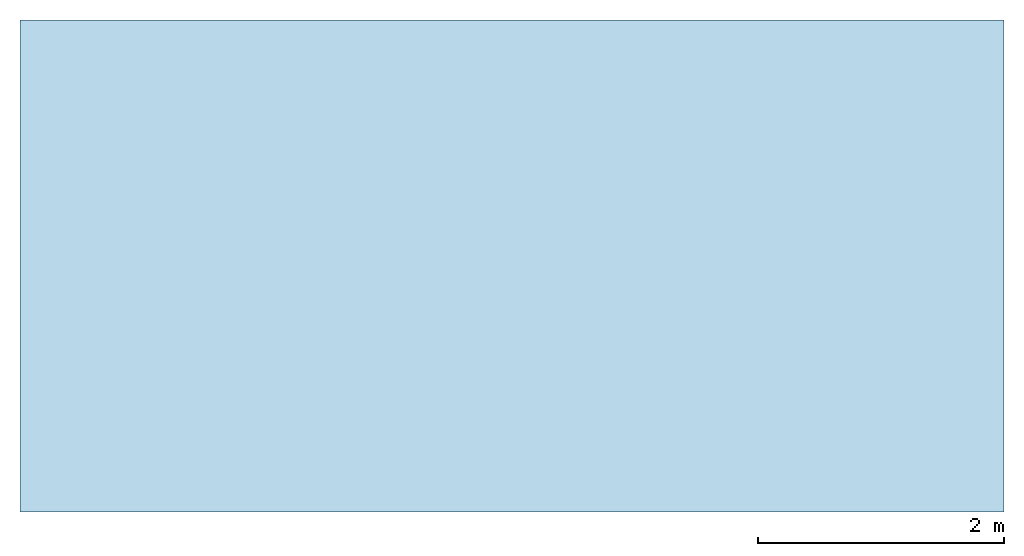
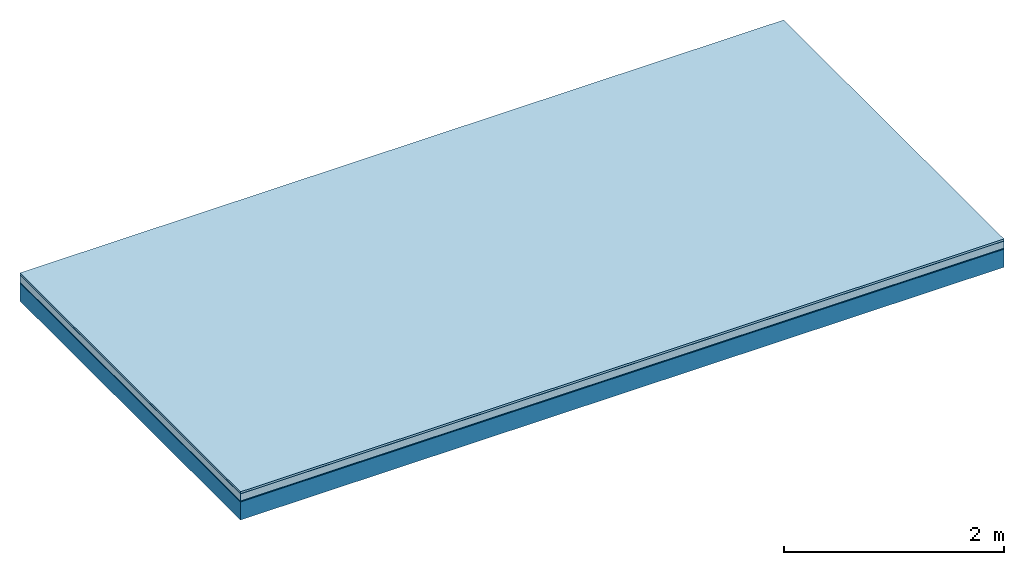
# One storey: 5 plates, 1 member, 1 element without a shape of its own.
"""IFC4 building model written with IfcOpenShell, lengths in metres."""

import ifcopenshell
import ifcopenshell.guid

model = None  # the IFC model being written
_history = None  # IfcOwnerHistory: only IFC2X3 demands one
_inside = {}  # id of a spatial element -> (the spatial element, [elements in it])
_under = {}  # id of a project, library or spatial element -> (it, [spatial elements below it])
_declared = {}  # id of a project -> (the project, [libraries it declares])
_typed = {}  # id of a type object -> (the type object, [elements of that type])
_made_of = {}  # id of a material, layer set ... -> (it, [elements and type objects made of it])


def new_model(schema):
    """Start an empty IFC model of exactly this schema.

    Asked for "IFC4X3", IfcOpenShell would pick the latest addendum, in which some entities
    have other attributes; the version numbers below select the first issue.
    IFC2X3 requires an IfcOwnerHistory on every rooted entity: one is made here for all.
    """
    global model, _history
    if schema == "IFC4X3":
        model = ifcopenshell.file(schema_version=(4, 3, 0, 0))
    else:
        model = ifcopenshell.file(schema=schema)
    _inside.clear()
    _under.clear()
    _declared.clear()
    _typed.clear()
    _made_of.clear()
    _history = None
    if model.schema == "IFC2X3":
        org = make("IfcOrganization", Name="unknown")
        user = make(
            "IfcPersonAndOrganization",
            ThePerson=make("IfcPerson", FamilyName="unknown"),
            TheOrganization=org,
        )
        app = make(
            "IfcApplication",
            ApplicationDeveloper=org,
            Version="unknown",
            ApplicationFullName="unknown",
            ApplicationIdentifier="unknown",
        )
        _history = make(
            "IfcOwnerHistory",
            OwningUser=user,
            OwningApplication=app,
            ChangeAction="ADDED",
            CreationDate=0,
        )
    return model


def make(cls, **values):
    """One entity of the class cls with the attributes given. An attribute that is None is left unset."""
    return model.create_entity(
        cls, **{name: value for name, value in values.items() if value is not None}
    )


def rooted(cls, **values):
    """An entity with a GlobalId (a new one), such as an element, a storey or a relation."""
    return make(cls, GlobalId=ifcopenshell.guid.new(), OwnerHistory=_history, **values)


def si_unit(unit_type, name, prefix=None):
    """IfcSIUnit, for example si_unit("LENGTHUNIT", "METRE", prefix="MILLI")."""
    return make("IfcSIUnit", UnitType=unit_type, Prefix=prefix, Name=name)


def derived_unit(unit_type, elements):
    """IfcDerivedUnit: a product of units, each with its exponent."""
    return make(
        "IfcDerivedUnit",
        Elements=[
            make("IfcDerivedUnitElement", Unit=unit, Exponent=power)
            for unit, power in elements
        ],
        UnitType=unit_type,
    )


def assignment(units):
    """IfcUnitAssignment: the units of a project."""
    return None if units is None else make("IfcUnitAssignment", Units=units)


def point(xyz):
    """IfcCartesianPoint."""
    return None if xyz is None else make("IfcCartesianPoint", Coordinates=xyz)


def direction(xyz):
    """IfcDirection."""
    return None if xyz is None else make("IfcDirection", DirectionRatios=xyz)


def frame(location, z_axis=None, x_axis=None):
    """IfcAxis2Placement3D, a coordinate frame: its origin and axes. An axis left out is left unset."""
    return make(
        "IfcAxis2Placement3D",
        Location=point(location),
        Axis=direction(z_axis),
        RefDirection=direction(x_axis),
    )


def frame_2d(location, x_axis=None):
    """IfcAxis2Placement2D, a coordinate frame in the plane: its origin and x axis."""
    return make(
        "IfcAxis2Placement2D", Location=point(location), RefDirection=direction(x_axis)
    )


def origin():
    """The frame at (0, 0, 0) with its axes left unset."""
    return frame((0.0, 0.0, 0.0))


def origin_with_axes():
    """The frame at (0, 0, 0) with the z axis (0, 0, 1) and the x axis (1, 0, 0) written out."""
    return frame((0.0, 0.0, 0.0), z_axis=(0.0, 0.0, 1.0), x_axis=(1.0, 0.0, 0.0))


def place(relative_to, where):
    """IfcLocalPlacement: puts the frame where relative to a parent placement (None: the world)."""
    return make(
        "IfcLocalPlacement", PlacementRelTo=relative_to, RelativePlacement=where
    )


def context(
    kind, dimensions, precision=None, world=None, true_north=None, identifier=None
):
    """IfcGeometricRepresentationContext, for example the 3D "Model" context."""
    return make(
        "IfcGeometricRepresentationContext",
        ContextIdentifier=identifier,
        ContextType=kind,
        CoordinateSpaceDimension=dimensions,
        Precision=precision,
        WorldCoordinateSystem=world,
        TrueNorth=true_north,
    )


def project(units=None, contexts=None):
    """IfcProject with its units and contexts."""
    return rooted(
        "IfcProject",
        Name="project",
        RepresentationContexts=contexts,
        UnitsInContext=assignment(units),
    )


def spatial(cls, under=None, at=None, **own):
    """A site, building, storey or space (cls), placed at a placement, below another one or the project."""
    s = rooted(cls, ObjectPlacement=at, **own)
    if under is not None:
        _under.setdefault(under.id(), (under, []))[1].append(s)
    return s


def profile(cls, at=None, kind="AREA", **sizes):
    """A parametric profile (cls). Its sizes go by their IFC names, for example OverallWidth=200.0."""
    return make(cls, ProfileType=kind, Position=at, **sizes)


def rectangle(**sizes):
    """IfcRectangleProfileDef."""
    return profile("IfcRectangleProfileDef", **sizes)


def extrude(swept, where, along, depth):
    """IfcExtrudedAreaSolid: the profile swept, set in the frame where, extruded along a direction by depth."""
    return make(
        "IfcExtrudedAreaSolid",
        SweptArea=swept,
        Position=where,
        ExtrudedDirection=direction(along),
        Depth=depth,
    )


def shape(context_of_items, identifier, shape_type, items):
    """IfcShapeRepresentation: the items that make up one representation, for example the "Body"."""
    return make(
        "IfcShapeRepresentation",
        ContextOfItems=context_of_items,
        RepresentationIdentifier=identifier,
        RepresentationType=shape_type,
        Items=items,
    )


def material(Name=None, Category=None):
    """IfcMaterial."""
    return make("IfcMaterial", Name=Name, Category=Category)


def layer(
    of_material, thickness, ventilated=None, Name=None, Category=None, Priority=None
):
    """IfcMaterialLayer: one layer of a wall or slab, of a material (None: an air gap)."""
    return make(
        "IfcMaterialLayer",
        Material=of_material,
        LayerThickness=thickness,
        IsVentilated=ventilated,
        Name=Name,
        Category=Category,
        Priority=Priority,
    )


def layer_set(layers, Name=None):
    """IfcMaterialLayerSet."""
    return make("IfcMaterialLayerSet", MaterialLayers=layers, LayerSetName=Name)


def made_of(thing, what):
    """Note that an element or type object is made of a material, layer set ...; save() writes the relation."""
    if what is not None:
        _made_of.setdefault(what.id(), (what, []))[1].append(thing)
    return thing


def type_object(cls, material=None, **own):
    """A type object (cls), such as IfcWallType, which elements share."""
    return made_of(rooted(cls, **own), material)


def element(
    cls,
    number,
    at=None,
    inside=None,
    cuts=None,
    type_object=None,
    material=None,
    context=None,
    identifier="Body",
    shape_type=None,
    held_by="IfcProductDefinitionShape",
    body=None,
    shapes=None,
    **own,
):
    """One element of the class cls, such as IfcWall. Its Tag is "e" and its number.

    at: its placement. inside: the storey or other place that contains it. cuts: it is an
    opening in that element (IfcRelVoidsElement). A single representation is given by context,
    identifier, shape_type and body (its items); several are given by shapes. held_by: the class
    of the entity that holds the representations. save() writes the other relations.
    """
    e = rooted(cls, Tag="e%d" % number, ObjectPlacement=at, **own)
    if body is not None:
        shapes = [shape(context, identifier, shape_type, body)]
    if shapes is not None:
        e.Representation = make(held_by, Representations=shapes)
    if inside is not None:
        _inside.setdefault(inside.id(), (inside, []))[1].append(e)
    if cuts is not None:
        rooted(
            "IfcRelVoidsElement", RelatingBuildingElement=cuts, RelatedOpeningElement=e
        )
    if type_object is not None:
        _typed.setdefault(type_object.id(), (type_object, []))[1].append(e)
    return made_of(e, material)


def aggregate(whole, parts):
    """IfcRelAggregates: a whole, such as a stair, and the parts it consists of."""
    return rooted("IfcRelAggregates", RelatingObject=whole, RelatedObjects=parts)


def save(model, path):
    """Write the relations noted so far, then the file.

    IfcRelAggregates (storeys below a building ...), IfcRelContainedInSpatialStructure (elements
    in a storey), IfcRelDefinesByType, IfcRelAssociatesMaterial and IfcRelDeclares: one each for
    every whole, place, type object, material and project.
    """
    for whole, parts in _under.values():
        aggregate(whole, parts)
    for where, things in _inside.values():
        rooted(
            "IfcRelContainedInSpatialStructure",
            RelatedElements=things,
            RelatingStructure=where,
        )
    for kind, things in _typed.values():
        rooted("IfcRelDefinesByType", RelatedObjects=things, RelatingType=kind)
    for what, things in _made_of.values():
        rooted("IfcRelAssociatesMaterial", RelatedObjects=things, RelatingMaterial=what)
    for by, libraries in _declared.values():
        rooted("IfcRelDeclares", RelatingContext=by, RelatedDefinitions=libraries)
    model.write(path)


model = new_model("IFC4")

# Units and contexts
plan_context = context("Plan", 3, precision=1e-05, world=origin(), true_north=direction((0.0, 1.0)))
model_context = context("Model", 3, precision=1e-05, world=origin(), true_north=direction((0.0, 1.0)))
ifc_project = project(units=[si_unit("LENGTHUNIT", "METRE"), derived_unit("SOUNDPRESSUREUNIT", [(si_unit("PRESSUREUNIT", "PASCAL", prefix="MICRO"), 0)]), si_unit("ENERGYUNIT", "JOULE", prefix="MEGA"), si_unit("MASSUNIT", "GRAM", prefix="KILO"), derived_unit("THERMALTRANSMITTANCEUNIT", [(si_unit("POWERUNIT", "WATT"), 1), (si_unit("AREAUNIT", "SQUARE_METRE"), -1), (si_unit("THERMODYNAMICTEMPERATUREUNIT", "KELVIN"), -1)]), derived_unit("AREADENSITYUNIT", [(si_unit("MASSUNIT", "GRAM", prefix="KILO"), 1), (si_unit("AREAUNIT", "SQUARE_METRE"), -1)]), derived_unit("USERDEFINED", [(si_unit("ENERGYUNIT", "JOULE", prefix="MEGA"), 1), (si_unit("AREAUNIT", "SQUARE_METRE"), -1)])], contexts=[plan_context, model_context])

# Site, building, storey
site = spatial("IfcSite", under=ifc_project)
building_placement = place(None, origin())
building = spatial("IfcBuilding", under=site, at=building_placement)
storey_placement = place(building_placement, origin())
storey = spatial("IfcBuildingStorey", under=building, at=storey_placement)

# Slab, member, plates
ifc_material_1 = material(Name="with tongue and groove", Category="07.009")
ifc_layer_1 = layer(ifc_material_1, 0.022, Name="Flooring")
ifc_material_2 = material(Category="09.006")
ifc_layer_2 = layer(ifc_material_2, 0.0005, Name="layer")
ifc_material_3 = material(Category="07.011")
ifc_layer_3 = layer(ifc_material_3, 0.08, Name="On-material")
ifc_material_4 = material(Name="Wood fiber generic product", Category="10.009")
ifc_layer_4 = layer(ifc_material_4, 0.01, Name="Impact sound insulation")
ifc_material_5 = material(Name="protection", Category="09.007")
ifc_layer_5 = layer(ifc_material_5, 0.0005, Name="Sub-floor")
ifc_material_6 = material(Name="no composite action")
ifc_layer_6 = layer(ifc_material_6, 0.0, Name="Bond")
ifc_layer_7 = layer(None, 0.2, Name="Supporting structure")
ifc_layer_set = layer_set([ifc_layer_1, ifc_layer_2, ifc_layer_3, ifc_layer_4, ifc_layer_5, ifc_layer_6, ifc_layer_7])
slab_type = type_object("IfcSlabType", Name="A2019", PredefinedType="NOTDEFINED", material=ifc_layer_set)
slab_placement = place(None, frame((0.0, 0.0, 0.0), z_axis=(0.0, 0.0, -1.0), x_axis=(1.0, 0.0, 0.0)))
slab = element("IfcSlab", 1, at=slab_placement, inside=storey, type_object=slab_type, material=ifc_layer_set, Name="Slab #1")
ifc_material_7 = material(Name="Solid timber panel")
member_placement = place(slab_placement, origin())
member = element("IfcMember", 2, at=member_placement, material=ifc_material_7, Name="Supporting structure", context=plan_context, shape_type="SweptSolid", body=[
    extrude(rectangle(XDim=1.0, YDim=0.2, at=frame_2d((0.5, 0.1), x_axis=(1.0, 0.0))), frame((0.0, 4.0, 0.113), z_axis=(0.0, -1.0, 0.0), x_axis=(1.0, 0.0, 0.0)), (0.0, 0.0, 1.0), 4.0),
    extrude(rectangle(XDim=1.0, YDim=0.2, at=frame_2d((0.5, 0.1), x_axis=(1.0, 0.0))), frame((1.0, 4.0, 0.113), z_axis=(0.0, -1.0, 0.0), x_axis=(1.0, 0.0, 0.0)), (0.0, 0.0, 1.0), 4.0),
    extrude(rectangle(XDim=1.0, YDim=0.2, at=frame_2d((0.5, 0.1), x_axis=(1.0, 0.0))), frame((2.0, 4.0, 0.113), z_axis=(0.0, -1.0, 0.0), x_axis=(1.0, 0.0, 0.0)), (0.0, 0.0, 1.0), 4.0),
    extrude(rectangle(XDim=1.0, YDim=0.2, at=frame_2d((0.5, 0.1), x_axis=(1.0, 0.0))), frame((3.0, 4.0, 0.113), z_axis=(0.0, -1.0, 0.0), x_axis=(1.0, 0.0, 0.0)), (0.0, 0.0, 1.0), 4.0),
    extrude(rectangle(XDim=1.0, YDim=0.2, at=frame_2d((0.5, 0.1), x_axis=(1.0, 0.0))), frame((4.0, 4.0, 0.113), z_axis=(0.0, -1.0, 0.0), x_axis=(1.0, 0.0, 0.0)), (0.0, 0.0, 1.0), 4.0),
    extrude(rectangle(XDim=1.0, YDim=0.2, at=frame_2d((0.5, 0.1), x_axis=(1.0, 0.0))), frame((5.0, 4.0, 0.113), z_axis=(0.0, -1.0, 0.0), x_axis=(1.0, 0.0, 0.0)), (0.0, 0.0, 1.0), 4.0),
    extrude(rectangle(XDim=1.0, YDim=0.2, at=frame_2d((0.5, 0.1), x_axis=(1.0, 0.0))), frame((6.0, 4.0, 0.113), z_axis=(0.0, -1.0, 0.0), x_axis=(1.0, 0.0, 0.0)), (0.0, 0.0, 1.0), 4.0),
    extrude(rectangle(XDim=1.0, YDim=0.2, at=frame_2d((0.5, 0.1), x_axis=(1.0, 0.0))), frame((7.0, 4.0, 0.113), z_axis=(0.0, -1.0, 0.0), x_axis=(1.0, 0.0, 0.0)), (0.0, 0.0, 1.0), 4.0),
])
plate_1_placement = place(slab_placement, origin())
plate_1 = element("IfcPlate", 3, at=plate_1_placement, material=ifc_material_1, Name="Flooring", context=plan_context, shape_type="SweptSolid", body=[
    extrude(rectangle(XDim=8.0, YDim=4.0, at=frame_2d((4.0, 2.0), x_axis=(1.0, 0.0))), origin_with_axes(), (0.0, 0.0, 1.0), 0.022),
])
plate_2_placement = place(slab_placement, origin())
plate_2 = element("IfcPlate", 4, at=plate_2_placement, material=ifc_material_2, Name="layer", context=plan_context, shape_type="SweptSolid", body=[
    extrude(rectangle(XDim=8.0, YDim=4.0, at=frame_2d((4.0, 2.0), x_axis=(1.0, 0.0))), frame((0.0, 0.0, 0.022), z_axis=(0.0, 0.0, 1.0), x_axis=(1.0, 0.0, 0.0)), (0.0, 0.0, 1.0), 0.0005),
])
plate_3_placement = place(slab_placement, origin())
plate_3 = element("IfcPlate", 5, at=plate_3_placement, material=ifc_material_3, Name="On-material", context=plan_context, shape_type="SweptSolid", body=[
    extrude(rectangle(XDim=8.0, YDim=4.0, at=frame_2d((4.0, 2.0), x_axis=(1.0, 0.0))), frame((0.0, 0.0, 0.0225), z_axis=(0.0, 0.0, 1.0), x_axis=(1.0, 0.0, 0.0)), (0.0, 0.0, 1.0), 0.08),
])
plate_4_placement = place(slab_placement, origin())
plate_4 = element("IfcPlate", 6, at=plate_4_placement, material=ifc_material_4, Name="Impact sound insulation", context=plan_context, shape_type="SweptSolid", body=[
    extrude(rectangle(XDim=8.0, YDim=4.0, at=frame_2d((4.0, 2.0), x_axis=(1.0, 0.0))), frame((0.0, 0.0, 0.1025), z_axis=(0.0, 0.0, 1.0), x_axis=(1.0, 0.0, 0.0)), (0.0, 0.0, 1.0), 0.01),
])
plate_5_placement = place(slab_placement, origin())
plate_5 = element("IfcPlate", 7, at=plate_5_placement, material=ifc_material_5, Name="Sub-floor", context=plan_context, shape_type="SweptSolid", body=[
    extrude(rectangle(XDim=8.0, YDim=4.0, at=frame_2d((4.0, 2.0), x_axis=(1.0, 0.0))), frame((0.0, 0.0, 0.1125), z_axis=(0.0, 0.0, 1.0), x_axis=(1.0, 0.0, 0.0)), (0.0, 0.0, 1.0), 0.0005),
])
aggregate(slab, [plate_1, plate_2, plate_3, plate_4, plate_5, member])

save(model, "model.ifc")
